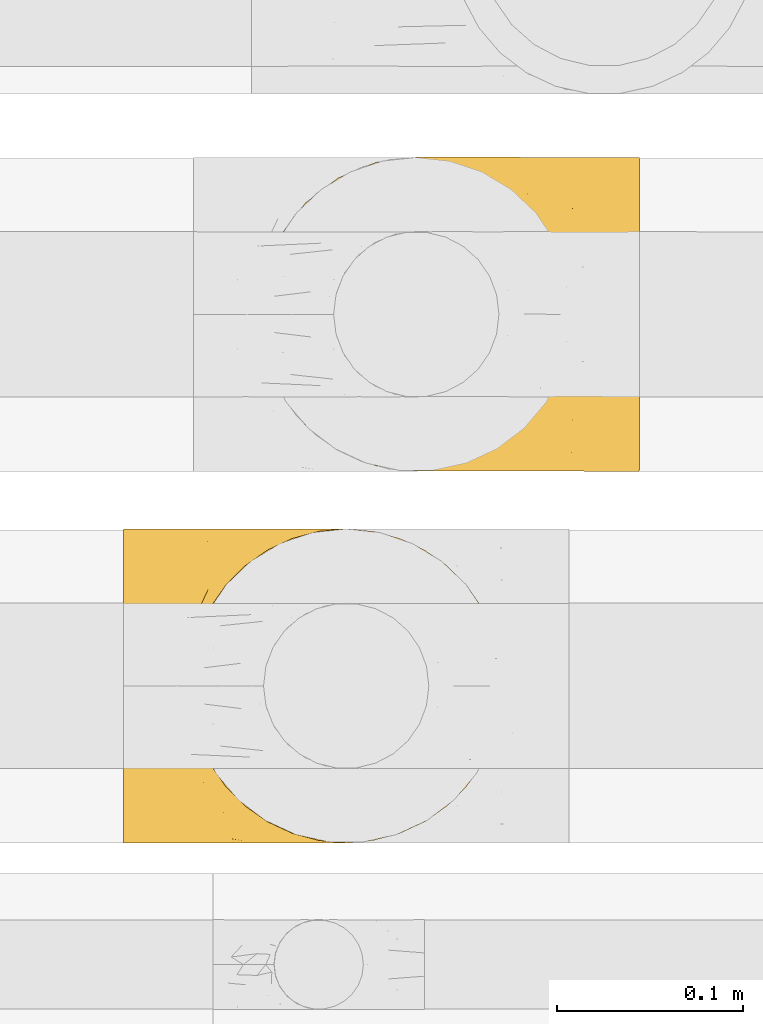
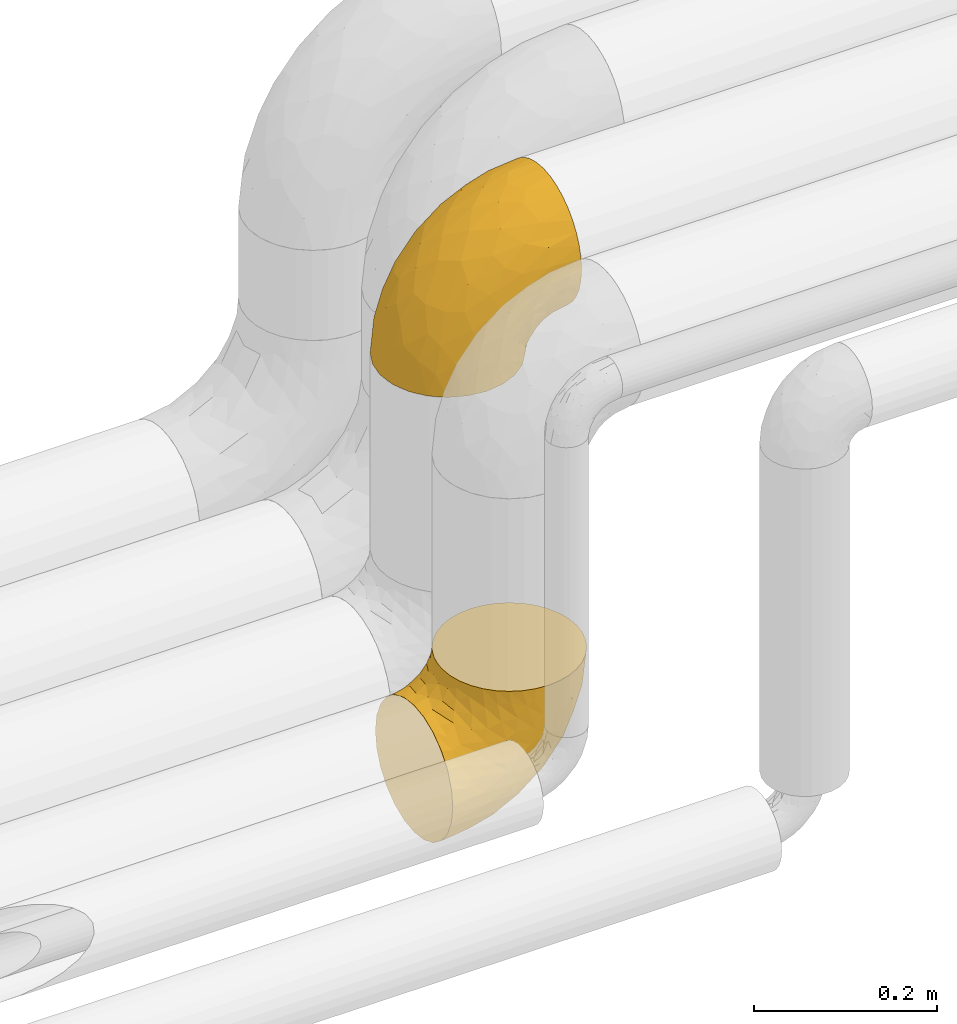
# One storey, part 16 of 93: 2 coverings.
"""IFC2X3 building model written with IfcOpenShell, lengths in millimetres."""

from ifc_helpers import new_model, entity, si_unit, converted_unit, derived_unit, direction, frame, origin, place, context, subcontext, project, spatial, faceted_brep, element, save


model = new_model("IFC2X3")

# Units and contexts
model_context = context("Model", 3, precision=0.01, world=origin(), true_north=direction((6.12303176911189e-17, 1.0)))
body_context = subcontext(model_context, "Body", "Model", "MODEL_VIEW")
ifc_project = project(units=[si_unit("LENGTHUNIT", "METRE", prefix="MILLI"), si_unit("AREAUNIT", "SQUARE_METRE"), si_unit("VOLUMEUNIT", "CUBIC_METRE"), converted_unit("PLANEANGLEUNIT", "DEGREE", entity("IfcRatioMeasure", 0.0174532925199433), si_unit("PLANEANGLEUNIT", "RADIAN"), dimensions=[0, 0, 0, 0, 0, 0, 0]), si_unit("MASSUNIT", "GRAM", prefix="KILO"), derived_unit("MASSDENSITYUNIT", [(si_unit("MASSUNIT", "GRAM", prefix="KILO"), 1), (si_unit("LENGTHUNIT", "METRE"), -3)]), derived_unit("MOMENTOFINERTIAUNIT", [(si_unit("LENGTHUNIT", "METRE"), 4)]), si_unit("TIMEUNIT", "SECOND"), si_unit("FREQUENCYUNIT", "HERTZ"), si_unit("THERMODYNAMICTEMPERATUREUNIT", "DEGREE_CELSIUS"), derived_unit("THERMALTRANSMITTANCEUNIT", [(si_unit("MASSUNIT", "GRAM", prefix="KILO"), 1), (si_unit("THERMODYNAMICTEMPERATUREUNIT", "KELVIN"), -1), (si_unit("TIMEUNIT", "SECOND"), -3)]), derived_unit("VOLUMETRICFLOWRATEUNIT", [(si_unit("LENGTHUNIT", "METRE"), 3), (si_unit("TIMEUNIT", "SECOND"), -1)]), derived_unit("MASSFLOWRATEUNIT", [(si_unit("MASSUNIT", "GRAM", prefix="KILO"), 1), (si_unit("TIMEUNIT", "SECOND"), -1)]), derived_unit("ROTATIONALFREQUENCYUNIT", [(si_unit("TIMEUNIT", "SECOND"), -1)]), si_unit("ELECTRICCURRENTUNIT", "AMPERE"), si_unit("ELECTRICVOLTAGEUNIT", "VOLT"), si_unit("POWERUNIT", "WATT"), si_unit("FORCEUNIT", "NEWTON", prefix="KILO"), si_unit("ILLUMINANCEUNIT", "LUX"), si_unit("LUMINOUSFLUXUNIT", "LUMEN"), si_unit("LUMINOUSINTENSITYUNIT", "CANDELA"), derived_unit("USERDEFINED", [(si_unit("MASSUNIT", "GRAM", prefix="KILO"), -1), (si_unit("LENGTHUNIT", "METRE"), -2), (si_unit("TIMEUNIT", "SECOND"), 3), (si_unit("LUMINOUSFLUXUNIT", "LUMEN"), 1)]), derived_unit("LINEARVELOCITYUNIT", [(si_unit("LENGTHUNIT", "METRE"), 1), (si_unit("TIMEUNIT", "SECOND"), -1)]), si_unit("PRESSUREUNIT", "PASCAL"), derived_unit("USERDEFINED", [(si_unit("LENGTHUNIT", "METRE"), -2), (si_unit("MASSUNIT", "GRAM", prefix="KILO"), 1), (si_unit("TIMEUNIT", "SECOND"), -2)]), derived_unit("LINEARFORCEUNIT", [(si_unit("MASSUNIT", "GRAM", prefix="KILO"), 1), (si_unit("LENGTHUNIT", "METRE"), 1), (si_unit("TIMEUNIT", "SECOND"), -2), (si_unit("LENGTHUNIT", "METRE"), -1)]), derived_unit("PLANARFORCEUNIT", [(si_unit("MASSUNIT", "GRAM", prefix="KILO"), 1), (si_unit("LENGTHUNIT", "METRE"), 1), (si_unit("TIMEUNIT", "SECOND"), -2), (si_unit("LENGTHUNIT", "METRE"), -2)])], contexts=[model_context])

# Site, building, storey
site_placement = place(None, origin())
site = spatial("IfcSite", under=ifc_project, at=site_placement, CompositionType="ELEMENT")
building_placement = place(site_placement, origin())
building = spatial("IfcBuilding", under=site, at=building_placement, CompositionType="ELEMENT")
storey_placement = place(building_placement, frame((0.0, 0.0, -4200.0)))
storey = spatial("IfcBuildingStorey", under=building, at=storey_placement, CompositionType="ELEMENT", Elevation=-4200.0)

# Coverings
covering_1_placement = place(storey_placement, frame((-2039.45, 14013.93, 2878.84)))
element("IfcCovering", 1, at=covering_1_placement, inside=storey, Name=":ADSK_", ObjectType=":ADSK_", PredefinedType="INSULATION", context=body_context, shape_type="Brep", body=[
    faceted_brep([(206.32, 165.5, 150.5), (206.33, 159.27, 163.85), (206.33, 150.82, 175.91), (206.33, 140.41, 186.33), (206.32, 128.34, 194.77), (206.32, 115.0, 201.0), (206.3, 100.77, 204.81), (206.29, 86.1, 206.1), (206.27, 71.42, 204.81), (206.25, 57.19, 201.0), (206.23, 43.84, 194.77), (206.21, 31.78, 186.32), (206.19, 21.36, 175.91), (206.17, 12.92, 163.84), (206.15, 6.69, 150.5), (206.13, 2.88, 136.27), (206.12, 1.6, 121.6), (206.11, 2.88, 106.92), (206.1, 6.69, 92.69), (206.09, 12.92, 79.34), (206.09, 21.37, 67.28), (206.09, 31.78, 56.86), (206.09, 43.85, 48.42), (206.1, 57.19, 42.19), (206.11, 71.42, 38.38), (206.13, 86.1, 37.1), (206.15, 100.77, 38.38), (206.16, 115.0, 42.19), (206.19, 128.35, 48.42), (206.21, 140.41, 56.87), (206.23, 150.83, 67.28), (206.25, 159.27, 79.35), (206.27, 165.5, 92.69), (206.28, 167.4, 99.81), (206.28, 169.31, 106.92), (206.3, 170.6, 121.6), (206.31, 169.31, 136.27), (128.27, 13.0, 1.6), (107.88, 4.58, 1.6), (99.47, 3.48, 1.6), (86.0, 1.72, 1.6), (64.14, 4.63, 1.6), (43.77, 13.09, 1.6), (26.28, 26.54, 1.6), (12.87, 44.05, 1.6), (4.45, 64.44, 1.6), (1.6, 86.32, 1.6), (4.5, 108.18, 1.6), (12.96, 128.55, 1.6), (26.41, 146.04, 1.6), (43.92, 159.45, 1.6), (64.31, 167.87, 1.6), (86.19, 170.72, 1.6), (99.65, 168.94, 1.6), (108.05, 167.82, 1.6), (118.24, 163.59, 1.6), (128.42, 159.36, 1.6), (145.91, 145.91, 1.6), (159.32, 128.4, 1.6), (167.74, 108.01, 1.6), (170.6, 86.13, 1.6), (167.69, 64.27, 1.6), (159.23, 43.9, 1.6), (145.78, 26.41, 1.6), (6.73, 86.31, 47.13), (21.87, 86.29, 90.37), (17.53, 102.01, 76.8), (7.76, 101.74, 45.15), (13.98, 115.52, 54.47), (96.77, 160.07, 119.79), (68.55, 153.68, 102.96), (78.91, 144.2, 130.99), (46.26, 86.27, 129.16), (33.91, 101.97, 109.15), (53.88, 161.92, 42.2), (110.38, 142.81, 157.21), (146.03, 150.81, 165.32), (119.01, 155.59, 145.45), (170.07, 143.13, 180.37), (63.09, 105.11, 144.76), (78.68, 86.23, 161.55), (99.87, 108.46, 172.83), (34.42, 151.29, 29.38), (21.38, 134.73, 42.46), (162.53, 119.13, 194.53), (140.45, 102.41, 193.6), (174.05, 105.32, 201.33), (73.5, 168.33, 46.42), (106.4, 168.01, 101.47), (135.71, 170.67, 98.72), (122.42, 170.69, 85.44), (109.13, 170.7, 72.17), (136.2, 164.18, 137.06), (139.88, 169.19, 120.01), (169.19, 170.64, 115.75), (152.45, 170.65, 107.23), (86.57, 168.09, 76.1), (100.6, 170.71, 55.43), (92.07, 170.72, 38.7), (51.36, 141.04, 101.68), (117.49, 86.19, 185.9), (127.96, 128.78, 178.03), (169.67, 160.42, 157.66), (40.72, 148.39, 65.31), (73.51, 163.05, 82.14), (80.37, 125.94, 150.07), (160.75, 86.14, 201.0), (168.12, 168.08, 136.96), (191.48, 170.61, 119.26), (180.34, 170.62, 117.51), (38.0, 120.2, 105.01), (32.95, 136.0, 75.54), (90.3, 170.72, 27.55), (88.53, 170.72, 16.41), (149.14, 157.13, 48.97), (161.48, 154.28, 55.5), (160.55, 145.09, 39.74), (124.98, 164.4, 35.55), (113.02, 169.26, 48.85), (124.51, 167.19, 51.94), (111.82, 167.77, 27.93), (104.2, 169.09, 19.58), (136.92, 156.89, 26.97), (129.67, 159.45, 16.32), (184.08, 144.98, 56.71), (174.87, 138.2, 44.94), (144.26, 148.7, 14.17), (188.36, 86.11, 32.35), (178.27, 104.96, 26.9), (190.57, 101.32, 35.04), (163.18, 123.58, 12.2), (192.0, 128.63, 46.4), (171.01, 104.06, 14.57), (174.57, 121.91, 31.45), (165.06, 129.9, 25.86), (190.35, 160.89, 80.67), (189.31, 153.12, 68.01), (171.54, 165.83, 86.74), (190.9, 169.25, 105.38), (185.27, 116.63, 37.13), (156.31, 167.0, 82.97), (169.14, 159.08, 69.5), (147.57, 165.76, 72.04), (185.32, 167.59, 96.92), (196.18, 112.06, 39.91), (155.59, 136.45, 14.18), (135.5, 165.5, 58.73), (137.43, 160.13, 40.81), (122.61, 169.52, 66.8), (175.36, 86.13, 19.35), (147.92, 148.04, 24.14), (178.23, 67.29, 26.9), (124.66, 3.44, 64.52), (140.3, 8.43, 58.42), (134.67, 3.67, 74.13), (190.54, 70.91, 35.04), (157.39, 29.28, 32.25), (167.0, 31.87, 40.67), (153.24, 18.79, 46.01), (170.98, 68.2, 14.58), (192.44, 43.84, 46.41), (185.66, 28.01, 56.6), (131.87, 8.34, 47.31), (148.12, 27.81, 12.22), (147.64, 23.6, 25.78), (137.22, 17.1, 20.4), (178.52, 34.06, 47.41), (106.15, 3.8, 18.51), (125.11, 10.36, 18.73), (109.92, 3.89, 32.35), (124.81, 7.97, 35.55), (115.94, 3.2, 53.81), (187.44, 3.07, 104.32), (185.21, 55.61, 37.13), (108.95, 1.7, 72.17), (196.13, 60.16, 39.91), (163.73, 18.46, 56.64), (191.3, 1.61, 119.26), (180.15, 1.62, 117.51), (90.12, 1.72, 27.55), (88.35, 1.72, 16.41), (189.77, 19.34, 67.84), (181.86, 8.97, 83.65), (163.86, 44.82, 20.63), (162.06, 3.82, 92.49), (173.38, 3.21, 100.09), (168.79, 12.03, 71.73), (142.34, 3.13, 84.27), (122.24, 1.69, 85.44), (169.01, 1.64, 115.75), (173.14, 48.42, 31.37), (150.66, 7.82, 70.4), (152.27, 1.65, 107.23), (135.53, 1.67, 98.72), (91.88, 1.72, 38.7), (100.42, 1.71, 55.43), (106.23, 4.4, 101.47), (90.9, 3.07, 72.23), (118.87, 16.78, 145.45), (169.51, 11.85, 157.66), (145.89, 21.51, 165.31), (33.88, 70.59, 109.15), (17.5, 70.59, 76.8), (37.92, 52.36, 105.01), (73.33, 4.15, 46.42), (73.35, 9.42, 82.14), (96.61, 12.36, 119.79), (53.71, 10.6, 42.21), (110.26, 29.58, 157.21), (78.77, 28.26, 130.98), (7.72, 70.88, 45.15), (167.95, 4.19, 136.95), (99.82, 63.96, 172.83), (63.05, 67.39, 144.76), (80.28, 46.52, 150.07), (13.92, 57.09, 54.47), (127.87, 43.58, 178.02), (34.28, 21.27, 29.38), (40.59, 24.15, 65.31), (68.41, 18.81, 102.96), (51.25, 31.47, 101.68), (169.95, 29.13, 180.37), (139.71, 3.14, 120.01), (136.05, 8.16, 137.06), (21.27, 37.85, 42.46), (32.85, 36.56, 75.55), (162.46, 53.15, 194.52), (140.42, 69.92, 193.6), (174.01, 66.93, 201.33)], [[[0, 1, 2, 3, 4, 5, 6, 7, 8, 9, 10, 11, 12, 13, 14, 15, 16, 17, 18, 19, 20, 21, 22, 23, 24, 25, 26, 27, 28, 29, 30, 31, 32, 33, 34, 35, 36]], [[37, 38, 39, 40, 41, 42, 43, 44, 45, 46, 47, 48, 49, 50, 51, 52, 53, 54, 55, 56, 57, 58, 59, 60, 61, 62, 63]], [[64, 65, 66]], [[67, 46, 64]], [[68, 48, 47]], [[69, 70, 71]], [[72, 73, 65]], [[50, 74, 51]], [[75, 76, 77]], [[65, 73, 66]], [[2, 78, 3]], [[79, 80, 81]], [[49, 82, 50]], [[49, 48, 83]], [[83, 48, 68]], [[84, 85, 86]], [[74, 87, 51]], [[88, 89, 90, 91]], [[92, 69, 77]], [[52, 51, 87]], [[93, 94, 95, 89]], [[92, 88, 69]], [[96, 91, 97, 98]], [[70, 99, 71]], [[81, 80, 100]], [[101, 81, 85]], [[76, 1, 102]], [[103, 104, 74]], [[5, 4, 84]], [[84, 4, 78]], [[80, 79, 72]], [[84, 86, 5]], [[77, 102, 92]], [[3, 78, 4]], [[101, 75, 105]], [[106, 7, 6]], [[100, 106, 85]], [[76, 78, 2]], [[107, 35, 108, 109, 94]], [[107, 94, 93]], [[93, 88, 92]], [[79, 105, 110]], [[99, 103, 111]], [[0, 107, 102]], [[84, 78, 101]], [[96, 98, 87]], [[66, 67, 64]], [[1, 76, 2]], [[0, 102, 1]], [[76, 101, 78]], [[107, 0, 36]], [[81, 100, 85]], [[88, 93, 89]], [[69, 88, 104]], [[107, 93, 92]], [[105, 79, 81]], [[73, 79, 110]], [[101, 105, 81]], [[105, 71, 99]], [[111, 68, 110]], [[82, 83, 103]], [[102, 107, 92]], [[107, 36, 35]], [[74, 50, 82]], [[87, 74, 104]], [[96, 87, 104]], [[87, 98, 112, 113, 52]], [[70, 69, 104]], [[77, 76, 102]], [[86, 106, 6]], [[85, 84, 101]], [[79, 73, 72]], [[66, 110, 68]], [[110, 66, 73]], [[66, 68, 67]], [[68, 47, 67]], [[46, 67, 47]], [[104, 103, 70]], [[99, 70, 103]], [[111, 103, 83]], [[105, 99, 110]], [[68, 111, 83]], [[110, 99, 111]], [[69, 71, 77]], [[75, 77, 71]], [[105, 75, 71]], [[101, 76, 75]], [[106, 86, 85]], [[5, 86, 6]], [[83, 82, 49]], [[74, 82, 103]], [[104, 88, 96]], [[91, 96, 88]], [[114, 115, 116]], [[113, 112, 54, 53, 52]], [[117, 118, 119]], [[120, 121, 98]], [[120, 98, 97]], [[117, 122, 123]], [[124, 125, 115]], [[58, 57, 126]], [[127, 128, 129]], [[115, 125, 116]], [[130, 59, 58]], [[28, 131, 124]], [[132, 60, 59]], [[133, 132, 134]], [[135, 136, 137]], [[138, 108, 34]], [[128, 139, 129]], [[89, 95, 140]], [[140, 141, 142]], [[32, 31, 143]], [[34, 33, 32, 138]], [[29, 124, 136]], [[141, 124, 115]], [[135, 31, 30]], [[116, 125, 133]], [[35, 34, 108]], [[28, 27, 131]], [[124, 141, 136]], [[144, 131, 27]], [[127, 129, 25]], [[139, 144, 129]], [[94, 109, 108, 138]], [[134, 130, 145]], [[28, 124, 29]], [[29, 136, 30]], [[121, 120, 55]], [[27, 26, 144]], [[124, 131, 125]], [[146, 114, 147]], [[115, 114, 142]], [[131, 139, 125]], [[117, 147, 122]], [[125, 139, 133]], [[135, 143, 31]], [[143, 137, 95]], [[142, 90, 89]], [[137, 136, 141]], [[146, 119, 148]], [[115, 142, 141]], [[119, 146, 147]], [[142, 146, 148]], [[141, 140, 137]], [[26, 25, 129]], [[131, 144, 139]], [[136, 135, 30]], [[143, 135, 137]], [[26, 129, 144]], [[128, 127, 149]], [[132, 128, 149]], [[133, 139, 128]], [[60, 132, 149]], [[132, 59, 130]], [[134, 150, 116]], [[119, 147, 117]], [[150, 114, 116]], [[142, 114, 146]], [[114, 150, 147]], [[122, 147, 150]], [[97, 118, 120]], [[148, 119, 91]], [[118, 117, 120]], [[119, 118, 91]], [[91, 118, 97]], [[123, 120, 117]], [[54, 112, 121]], [[91, 90, 148]], [[142, 148, 90]], [[132, 133, 128]], [[133, 134, 116]], [[142, 89, 140]], [[94, 143, 95]], [[150, 126, 122]], [[123, 57, 56]], [[123, 122, 126]], [[120, 123, 56]], [[126, 150, 145]], [[123, 126, 57]], [[140, 95, 137]], [[145, 130, 58]], [[132, 130, 134]], [[126, 145, 58]], [[134, 145, 150]], [[32, 143, 138]], [[94, 138, 143]], [[121, 112, 98]], [[120, 56, 55]], [[54, 121, 55]], [[149, 127, 151]], [[152, 153, 154]], [[127, 155, 151]], [[156, 157, 158]], [[159, 149, 151]], [[159, 60, 149]], [[160, 22, 161]], [[153, 152, 162]], [[163, 164, 165]], [[166, 160, 161]], [[167, 37, 168]], [[169, 170, 171]], [[169, 168, 170]], [[168, 165, 170]], [[172, 19, 18]], [[166, 173, 160]], [[174, 171, 152]], [[24, 175, 155]], [[176, 158, 157]], [[17, 16, 177, 178]], [[38, 167, 179]], [[160, 23, 22]], [[175, 24, 23]], [[180, 40, 39, 38, 179]], [[20, 181, 21]], [[182, 20, 19]], [[21, 181, 161]], [[21, 161, 22]], [[62, 61, 183]], [[184, 182, 185]], [[186, 161, 181]], [[172, 18, 17]], [[187, 188, 154]], [[161, 176, 166]], [[185, 19, 172]], [[178, 189, 172]], [[178, 172, 17]], [[151, 173, 190]], [[164, 163, 183]], [[155, 25, 24]], [[166, 176, 157]], [[175, 160, 173]], [[153, 176, 191]], [[20, 182, 181]], [[186, 181, 182]], [[185, 182, 19]], [[172, 189, 185]], [[189, 192, 185]], [[187, 184, 193]], [[184, 185, 192]], [[160, 175, 23]], [[155, 175, 173]], [[155, 173, 151]], [[155, 127, 25]], [[173, 166, 190]], [[159, 183, 61]], [[193, 184, 192]], [[186, 182, 184]], [[159, 151, 190]], [[60, 159, 61]], [[176, 161, 186]], [[166, 157, 190]], [[191, 176, 186]], [[158, 176, 153]], [[187, 186, 184]], [[191, 154, 153]], [[156, 190, 157]], [[188, 152, 154]], [[159, 190, 183]], [[162, 158, 153]], [[156, 158, 164]], [[164, 183, 156]], [[190, 156, 183]], [[187, 154, 191]], [[152, 188, 174]], [[171, 170, 162]], [[152, 171, 162]], [[167, 169, 194]], [[169, 195, 194]], [[169, 167, 168]], [[174, 195, 171]], [[169, 171, 195]], [[165, 162, 170]], [[158, 162, 164]], [[187, 191, 186]], [[188, 187, 193]], [[37, 167, 38]], [[37, 63, 168]], [[165, 164, 162]], [[168, 63, 165]], [[163, 165, 63]], [[63, 62, 163]], [[183, 163, 62]], [[167, 194, 179]], [[196, 197, 174]], [[198, 199, 200]], [[201, 202, 203]], [[204, 40, 180, 179, 194]], [[205, 196, 206]], [[204, 205, 207]], [[204, 197, 205]], [[196, 174, 188, 193]], [[198, 208, 209]], [[65, 201, 72]], [[46, 45, 210]], [[211, 189, 178, 177, 16]], [[212, 213, 214]], [[45, 44, 215]], [[214, 216, 212]], [[217, 207, 218]], [[218, 219, 220]], [[210, 215, 202]], [[199, 13, 200]], [[217, 43, 42]], [[213, 80, 72]], [[221, 12, 11]], [[222, 193, 192, 189]], [[199, 223, 211]], [[16, 15, 211]], [[212, 100, 80]], [[216, 200, 221]], [[199, 211, 14]], [[14, 13, 199]], [[206, 196, 223]], [[12, 221, 200]], [[215, 224, 225]], [[222, 196, 193]], [[13, 12, 200]], [[221, 11, 10]], [[10, 226, 221]], [[80, 213, 212]], [[226, 227, 216]], [[212, 216, 227]], [[226, 10, 9]], [[228, 106, 227]], [[100, 227, 106]], [[7, 106, 8]], [[44, 224, 215]], [[228, 9, 8]], [[216, 221, 226]], [[223, 198, 206]], [[41, 207, 42]], [[219, 205, 206]], [[223, 222, 211]], [[44, 43, 224]], [[64, 210, 202]], [[196, 222, 223]], [[201, 213, 72]], [[203, 220, 214]], [[203, 214, 213]], [[214, 209, 208]], [[217, 224, 43]], [[218, 220, 225]], [[189, 211, 222]], [[211, 15, 14]], [[41, 40, 204]], [[218, 207, 205]], [[41, 204, 207]], [[197, 194, 195, 174]], [[223, 199, 198]], [[219, 206, 209]], [[212, 227, 100]], [[228, 227, 226]], [[202, 201, 65]], [[213, 201, 203]], [[64, 202, 65]], [[203, 202, 215]], [[46, 210, 64]], [[45, 215, 210]], [[220, 219, 209]], [[218, 205, 219]], [[214, 220, 209]], [[218, 225, 224]], [[220, 203, 225]], [[215, 225, 203]], [[208, 198, 200]], [[209, 206, 198]], [[200, 216, 208]], [[214, 208, 216]], [[9, 228, 226]], [[106, 228, 8]], [[207, 217, 42]], [[224, 217, 218]], [[205, 197, 196]], [[194, 197, 204]]]),
])
covering_2_placement = place(storey_placement, frame((-2112.69, 13813.91, 2417.55)))
element("IfcCovering", 2, at=covering_2_placement, inside=storey, Name=":ADSK_", ObjectType=":ADSK_", PredefinedType="INSULATION", context=body_context, shape_type="Brep", body=[
    faceted_brep([(150.5, 6.69, 206.1), (163.85, 12.92, 206.1), (175.91, 21.37, 206.1), (186.33, 31.78, 206.1), (194.77, 43.85, 206.1), (201.0, 57.19, 206.1), (204.81, 71.42, 206.1), (206.1, 86.1, 206.1), (204.81, 100.77, 206.1), (201.0, 115.0, 206.1), (194.77, 128.35, 206.1), (186.32, 140.41, 206.1), (175.91, 150.83, 206.1), (163.84, 159.27, 206.1), (150.5, 165.5, 206.1), (136.27, 169.31, 206.1), (121.6, 170.6, 206.1), (106.92, 169.31, 206.1), (92.69, 165.5, 206.1), (79.34, 159.27, 206.1), (67.28, 150.82, 206.1), (56.86, 140.41, 206.1), (48.42, 128.34, 206.1), (42.19, 115.0, 206.1), (38.38, 100.77, 206.1), (37.1, 86.1, 206.1), (38.38, 71.42, 206.1), (42.19, 57.19, 206.1), (48.42, 43.84, 206.1), (56.87, 31.78, 206.1), (67.28, 21.36, 206.1), (79.35, 12.92, 206.1), (92.69, 6.69, 206.1), (99.81, 4.79, 206.1), (106.92, 2.88, 206.1), (121.6, 1.6, 206.1), (136.27, 2.88, 206.1), (1.6, 86.1, 170.6), (1.6, 107.97, 167.72), (1.6, 128.35, 159.27), (1.6, 145.85, 145.85), (1.6, 159.27, 128.35), (1.6, 167.72, 107.97), (1.6, 168.82, 99.56), (1.6, 170.6, 86.1), (1.6, 167.72, 64.23), (1.6, 159.27, 43.85), (1.6, 145.85, 26.34), (1.6, 128.35, 12.92), (1.6, 107.97, 4.47), (1.6, 86.1, 1.6), (1.6, 64.23, 4.47), (1.6, 43.85, 12.92), (1.6, 26.34, 26.34), (1.6, 12.92, 43.85), (1.6, 4.47, 64.23), (1.6, 1.6, 86.1), (1.6, 3.37, 99.56), (1.6, 4.47, 107.97), (1.6, 8.7, 118.16), (1.6, 12.92, 128.35), (1.6, 26.34, 145.85), (1.6, 43.85, 159.27), (1.6, 64.23, 167.72), (47.1, 86.1, 6.72), (90.32, 86.1, 21.85), (76.74, 70.39, 17.49), (45.07, 70.66, 7.72), (54.43, 56.88, 13.94), (130.85, 28.12, 78.7), (102.9, 18.64, 68.47), (101.57, 31.21, 51.33), (129.1, 86.1, 46.21), (109.1, 70.41, 33.86), (42.18, 10.43, 53.79), (157.11, 29.48, 110.17), (165.26, 21.45, 145.81), (145.37, 16.68, 118.82), (180.34, 29.1, 169.84), (144.69, 67.25, 63.0), (161.48, 86.1, 78.59), (172.76, 63.85, 99.74), (29.38, 21.08, 34.35), (42.46, 37.65, 21.32), (194.48, 53.11, 162.31), (193.55, 69.85, 140.29), (201.3, 66.89, 173.87), (46.37, 4.01, 73.41), (101.41, 4.29, 106.28), (98.68, 1.6, 135.56), (85.4, 1.6, 122.29), (72.13, 1.6, 109.01), (137.0, 8.08, 136.01), (119.7, 12.22, 96.64), (119.97, 3.07, 139.72), (115.72, 1.6, 169.01), (107.2, 1.6, 152.29), (76.04, 4.22, 86.47), (55.4, 1.6, 100.49), (38.68, 1.6, 91.97), (185.84, 86.1, 117.37), (177.95, 43.5, 127.74), (157.62, 11.81, 169.45), (65.3, 23.97, 40.66), (82.09, 9.27, 73.41), (149.99, 46.38, 80.23), (200.97, 86.1, 160.59), (136.93, 4.15, 167.92), (119.25, 1.6, 191.28), (117.49, 1.6, 180.15), (104.96, 52.19, 37.92), (75.57, 36.38, 32.9), (27.54, 1.6, 90.21), (16.41, 1.6, 88.44), (48.91, 15.12, 149.02), (55.45, 17.96, 161.35), (39.69, 27.16, 160.46), (35.54, 7.89, 124.9), (48.76, 3.04, 112.91), (52.0, 5.06, 124.31), (27.71, 4.56, 111.82), (19.57, 3.21, 104.11), (26.99, 15.37, 136.85), (16.3, 12.85, 129.63), (56.69, 27.24, 183.96), (44.9, 34.03, 174.77), (14.18, 23.54, 144.17), (32.34, 86.1, 188.35), (26.88, 67.27, 178.24), (35.03, 70.89, 190.53), (12.19, 48.67, 163.14), (46.38, 43.58, 191.92), (14.56, 68.19, 170.99), (31.42, 50.33, 174.51), (25.84, 42.35, 165.01), (80.65, 11.32, 190.2), (67.99, 19.09, 189.17), (86.7, 6.4, 171.39), (105.36, 2.96, 190.71), (37.11, 55.59, 185.21), (82.94, 5.24, 156.15), (69.47, 13.15, 168.99), (71.96, 6.52, 147.47), (96.9, 4.62, 185.14), (39.9, 60.15, 196.12), (14.17, 35.8, 155.54), (58.72, 6.76, 135.37), (40.86, 12.09, 137.28), (66.83, 2.76, 122.5), (19.35, 86.1, 175.35), (24.13, 24.23, 147.86), (26.89, 104.92, 178.24), (64.55, 168.84, 124.75), (58.43, 163.83, 140.4), (74.15, 168.6, 134.79), (35.03, 101.29, 190.53), (32.21, 142.93, 157.46), (40.64, 140.34, 167.05), (45.95, 153.44, 153.29), (14.56, 104.01, 170.99), (46.39, 128.36, 192.44), (56.57, 144.2, 185.67), (47.33, 163.94, 131.94), (12.22, 144.45, 148.18), (25.77, 148.65, 147.71), (20.39, 155.16, 137.3), (47.38, 138.15, 178.55), (18.5, 168.5, 106.23), (18.72, 161.91, 125.2), (32.32, 168.4, 110.01), (35.54, 164.3, 124.9), (53.79, 169.08, 116.08), (104.3, 169.14, 187.44), (37.11, 116.59, 185.21), (72.13, 170.6, 109.01), (39.9, 112.04, 196.13), (56.59, 153.76, 163.78), (119.25, 170.6, 191.28), (117.49, 170.6, 180.15), (27.54, 170.6, 90.21), (16.41, 170.6, 88.44), (67.82, 152.86, 189.79), (83.63, 163.25, 181.87), (20.61, 127.4, 163.9), (92.44, 168.42, 162.06), (100.06, 169.02, 173.37), (71.69, 160.2, 168.81), (84.22, 169.11, 142.59), (85.4, 170.6, 122.29), (115.72, 170.6, 169.01), (31.34, 123.79, 173.17), (70.29, 164.38, 150.79), (107.2, 170.6, 152.29), (98.68, 170.6, 135.56), (38.68, 170.6, 91.97), (55.4, 170.6, 100.49), (101.41, 167.9, 106.28), (72.18, 169.24, 90.96), (145.37, 155.51, 118.83), (157.62, 160.38, 169.45), (165.25, 150.75, 145.81), (109.1, 101.78, 33.86), (76.74, 101.8, 17.49), (104.96, 120.0, 37.92), (46.36, 168.19, 73.4), (82.09, 162.92, 73.41), (119.7, 159.97, 96.64), (42.18, 161.76, 53.79), (157.11, 142.72, 110.16), (130.84, 144.07, 78.7), (45.07, 101.53, 7.72), (136.93, 168.04, 167.93), (172.76, 108.34, 99.74), (144.69, 104.94, 63.0), (149.99, 125.82, 80.23), (54.43, 115.31, 13.94), (177.94, 128.7, 127.74), (29.38, 151.11, 34.35), (65.31, 148.22, 40.66), (75.58, 135.81, 32.91), (42.46, 134.54, 21.32), (180.33, 143.1, 169.84), (119.97, 169.12, 139.72), (137.0, 164.11, 136.02), (102.89, 153.55, 68.47), (101.56, 140.99, 51.33), (194.48, 119.09, 162.31), (193.55, 102.34, 140.29), (201.3, 105.31, 173.87)], [[[0, 1, 2, 3, 4, 5, 6, 7, 8, 9, 10, 11, 12, 13, 14, 15, 16, 17, 18, 19, 20, 21, 22, 23, 24, 25, 26, 27, 28, 29, 30, 31, 32, 33, 34, 35, 36]], [[37, 38, 39, 40, 41, 42, 43, 44, 45, 46, 47, 48, 49, 50, 51, 52, 53, 54, 55, 56, 57, 58, 59, 60, 61, 62, 63]], [[64, 65, 66]], [[67, 50, 64]], [[68, 52, 51]], [[69, 70, 71]], [[72, 73, 65]], [[54, 74, 55]], [[75, 76, 77]], [[65, 73, 66]], [[2, 78, 3]], [[79, 80, 81]], [[53, 82, 54]], [[53, 52, 83]], [[52, 68, 83]], [[84, 85, 86]], [[74, 87, 55]], [[88, 89, 90, 91]], [[92, 93, 77]], [[56, 55, 87]], [[94, 95, 96, 89]], [[92, 88, 93]], [[97, 91, 98, 99]], [[93, 70, 69]], [[81, 80, 100]], [[101, 81, 85]], [[76, 1, 102]], [[74, 103, 104]], [[5, 4, 84]], [[84, 4, 78]], [[80, 79, 72]], [[84, 86, 5]], [[77, 102, 92]], [[3, 78, 4]], [[101, 75, 105]], [[106, 7, 6]], [[100, 106, 85]], [[76, 78, 2]], [[107, 35, 108, 109, 95]], [[107, 95, 94]], [[94, 88, 92]], [[79, 105, 110]], [[71, 103, 111]], [[0, 107, 102]], [[84, 78, 101]], [[97, 99, 87]], [[66, 67, 64]], [[1, 76, 2]], [[0, 102, 1]], [[76, 101, 78]], [[107, 0, 36]], [[81, 100, 85]], [[88, 94, 89]], [[93, 88, 104]], [[107, 94, 92]], [[105, 79, 81]], [[73, 79, 110]], [[101, 105, 81]], [[105, 69, 71]], [[111, 68, 110]], [[82, 83, 103]], [[102, 107, 92]], [[107, 36, 35]], [[74, 54, 82]], [[87, 74, 104]], [[97, 87, 104]], [[87, 99, 112, 113, 56]], [[70, 93, 104]], [[77, 76, 102]], [[86, 106, 6]], [[85, 84, 101]], [[79, 73, 72]], [[66, 110, 68]], [[110, 66, 73]], [[66, 68, 67]], [[68, 51, 67]], [[50, 67, 51]], [[104, 103, 70]], [[71, 70, 103]], [[111, 103, 83]], [[105, 71, 110]], [[68, 111, 83]], [[110, 71, 111]], [[93, 69, 77]], [[75, 77, 69]], [[105, 75, 69]], [[101, 76, 75]], [[106, 86, 85]], [[5, 86, 6]], [[83, 82, 53]], [[74, 82, 103]], [[104, 88, 97]], [[91, 97, 88]], [[114, 115, 116]], [[113, 112, 58, 57, 56]], [[117, 118, 119]], [[120, 121, 99]], [[120, 99, 98]], [[117, 122, 123]], [[124, 125, 115]], [[62, 61, 126]], [[127, 128, 129]], [[115, 125, 116]], [[130, 63, 62]], [[28, 131, 124]], [[132, 37, 63]], [[133, 132, 134]], [[135, 136, 137]], [[138, 108, 34]], [[128, 139, 129]], [[89, 96, 140]], [[140, 141, 142]], [[32, 31, 143]], [[34, 33, 32, 138]], [[29, 124, 136]], [[141, 124, 115]], [[135, 31, 30]], [[116, 125, 133]], [[35, 34, 108]], [[28, 27, 131]], [[124, 141, 136]], [[144, 131, 27]], [[127, 129, 25]], [[139, 144, 129]], [[95, 109, 108, 138]], [[134, 130, 145]], [[28, 124, 29]], [[29, 136, 30]], [[121, 120, 59]], [[27, 26, 144]], [[124, 131, 125]], [[146, 114, 147]], [[115, 114, 142]], [[131, 139, 125]], [[117, 147, 122]], [[125, 139, 133]], [[135, 143, 31]], [[143, 137, 96]], [[142, 90, 89]], [[137, 136, 141]], [[146, 119, 148]], [[115, 142, 141]], [[119, 146, 147]], [[142, 146, 148]], [[141, 140, 137]], [[26, 25, 129]], [[131, 144, 139]], [[136, 135, 30]], [[143, 135, 137]], [[26, 129, 144]], [[128, 127, 149]], [[132, 128, 149]], [[133, 139, 128]], [[37, 132, 149]], [[132, 63, 130]], [[134, 150, 116]], [[119, 147, 117]], [[150, 114, 116]], [[142, 114, 146]], [[114, 150, 147]], [[122, 147, 150]], [[98, 118, 120]], [[148, 119, 91]], [[118, 117, 120]], [[119, 118, 91]], [[91, 118, 98]], [[123, 120, 117]], [[58, 112, 121]], [[91, 90, 148]], [[142, 148, 90]], [[132, 133, 128]], [[133, 134, 116]], [[142, 89, 140]], [[95, 143, 96]], [[150, 126, 122]], [[123, 61, 60]], [[123, 122, 126]], [[120, 123, 60]], [[126, 150, 145]], [[123, 126, 61]], [[140, 96, 137]], [[145, 130, 62]], [[132, 130, 134]], [[126, 145, 62]], [[134, 145, 150]], [[32, 143, 138]], [[95, 138, 143]], [[121, 112, 99]], [[120, 60, 59]], [[58, 121, 59]], [[149, 127, 151]], [[152, 153, 154]], [[127, 155, 151]], [[156, 157, 158]], [[159, 149, 151]], [[159, 37, 149]], [[160, 22, 161]], [[153, 152, 162]], [[163, 164, 165]], [[166, 160, 161]], [[167, 41, 168]], [[169, 170, 171]], [[169, 168, 170]], [[168, 165, 170]], [[172, 19, 18]], [[166, 173, 160]], [[174, 171, 152]], [[24, 175, 155]], [[176, 158, 157]], [[17, 16, 177, 178]], [[42, 167, 179]], [[160, 23, 22]], [[175, 24, 23]], [[180, 44, 43, 42, 179]], [[20, 181, 21]], [[182, 20, 19]], [[21, 181, 161]], [[21, 161, 22]], [[39, 38, 183]], [[184, 182, 185]], [[186, 161, 181]], [[172, 18, 17]], [[187, 188, 154]], [[161, 176, 166]], [[185, 19, 172]], [[178, 189, 172]], [[178, 172, 17]], [[151, 173, 190]], [[164, 163, 183]], [[155, 25, 24]], [[166, 176, 157]], [[175, 160, 173]], [[153, 176, 191]], [[20, 182, 181]], [[186, 181, 182]], [[185, 182, 19]], [[172, 189, 185]], [[189, 192, 185]], [[187, 184, 193]], [[184, 185, 192]], [[160, 175, 23]], [[155, 175, 173]], [[155, 173, 151]], [[155, 127, 25]], [[173, 166, 190]], [[159, 183, 38]], [[193, 184, 192]], [[186, 182, 184]], [[159, 151, 190]], [[37, 159, 38]], [[176, 161, 186]], [[166, 157, 190]], [[191, 176, 186]], [[158, 176, 153]], [[187, 186, 184]], [[191, 154, 153]], [[156, 190, 157]], [[188, 152, 154]], [[159, 190, 183]], [[162, 158, 153]], [[156, 158, 164]], [[164, 183, 156]], [[190, 156, 183]], [[187, 154, 191]], [[152, 188, 174]], [[171, 170, 162]], [[152, 171, 162]], [[167, 169, 194]], [[169, 195, 194]], [[169, 167, 168]], [[174, 195, 171]], [[169, 171, 195]], [[165, 162, 170]], [[158, 162, 164]], [[187, 191, 186]], [[188, 187, 193]], [[41, 167, 42]], [[41, 40, 168]], [[165, 164, 162]], [[168, 40, 165]], [[163, 165, 40]], [[40, 39, 163]], [[183, 163, 39]], [[167, 194, 179]], [[196, 197, 174]], [[198, 199, 200]], [[201, 202, 203]], [[204, 44, 180, 179, 194]], [[205, 196, 206]], [[204, 205, 207]], [[204, 197, 205]], [[196, 174, 188, 193]], [[198, 208, 209]], [[65, 201, 72]], [[50, 49, 210]], [[211, 189, 178, 177, 16]], [[212, 213, 214]], [[49, 48, 215]], [[214, 216, 212]], [[217, 207, 218]], [[217, 47, 46]], [[210, 215, 202]], [[199, 13, 200]], [[219, 215, 220]], [[213, 80, 72]], [[221, 12, 11]], [[222, 193, 192, 189]], [[199, 223, 211]], [[16, 15, 211]], [[212, 100, 80]], [[216, 200, 221]], [[199, 211, 14]], [[14, 13, 199]], [[206, 196, 223]], [[12, 221, 200]], [[218, 224, 225]], [[222, 196, 193]], [[13, 12, 200]], [[221, 11, 10]], [[10, 226, 221]], [[80, 213, 212]], [[226, 227, 216]], [[212, 216, 227]], [[226, 10, 9]], [[228, 106, 227]], [[100, 227, 106]], [[7, 106, 8]], [[48, 220, 215]], [[228, 9, 8]], [[216, 221, 226]], [[223, 198, 206]], [[45, 207, 46]], [[206, 224, 205]], [[223, 222, 211]], [[48, 47, 220]], [[64, 210, 202]], [[196, 222, 223]], [[201, 213, 72]], [[203, 225, 214]], [[203, 214, 213]], [[214, 209, 208]], [[217, 220, 47]], [[218, 225, 219]], [[189, 211, 222]], [[211, 15, 14]], [[45, 44, 204]], [[218, 207, 205]], [[45, 204, 207]], [[197, 194, 195, 174]], [[223, 199, 198]], [[224, 206, 209]], [[212, 227, 100]], [[228, 227, 226]], [[202, 201, 65]], [[213, 201, 203]], [[64, 202, 65]], [[203, 202, 215]], [[50, 210, 64]], [[49, 215, 210]], [[225, 224, 209]], [[218, 205, 224]], [[214, 225, 209]], [[218, 219, 220]], [[225, 203, 219]], [[215, 219, 203]], [[208, 198, 200]], [[209, 206, 198]], [[200, 216, 208]], [[214, 208, 216]], [[9, 228, 226]], [[106, 228, 8]], [[207, 217, 46]], [[220, 217, 218]], [[205, 197, 196]], [[194, 197, 204]]]),
])

save(model, "model.ifc")
